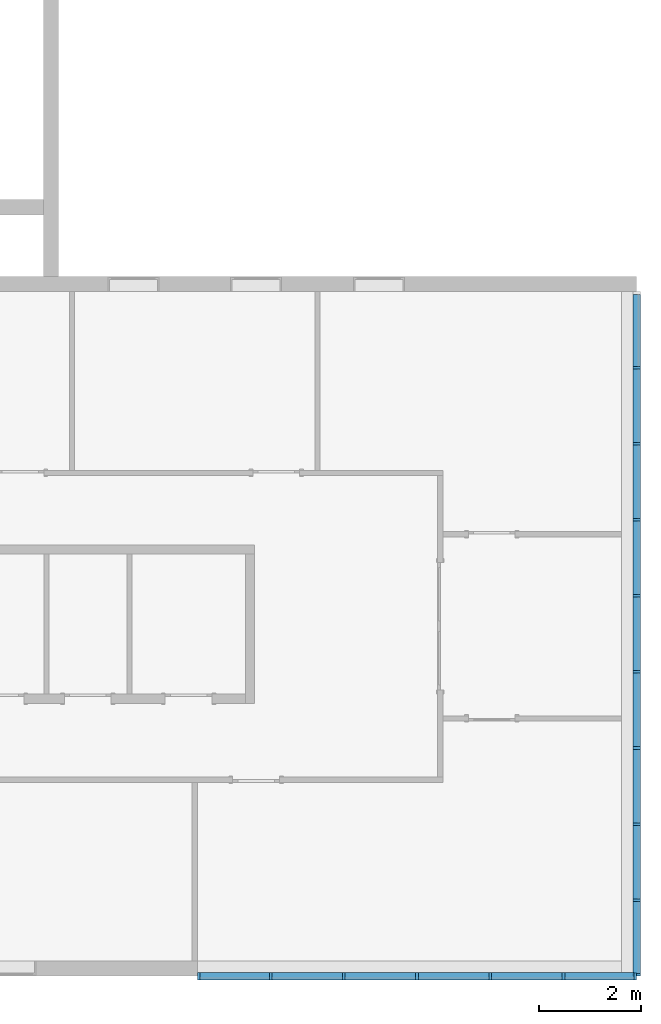
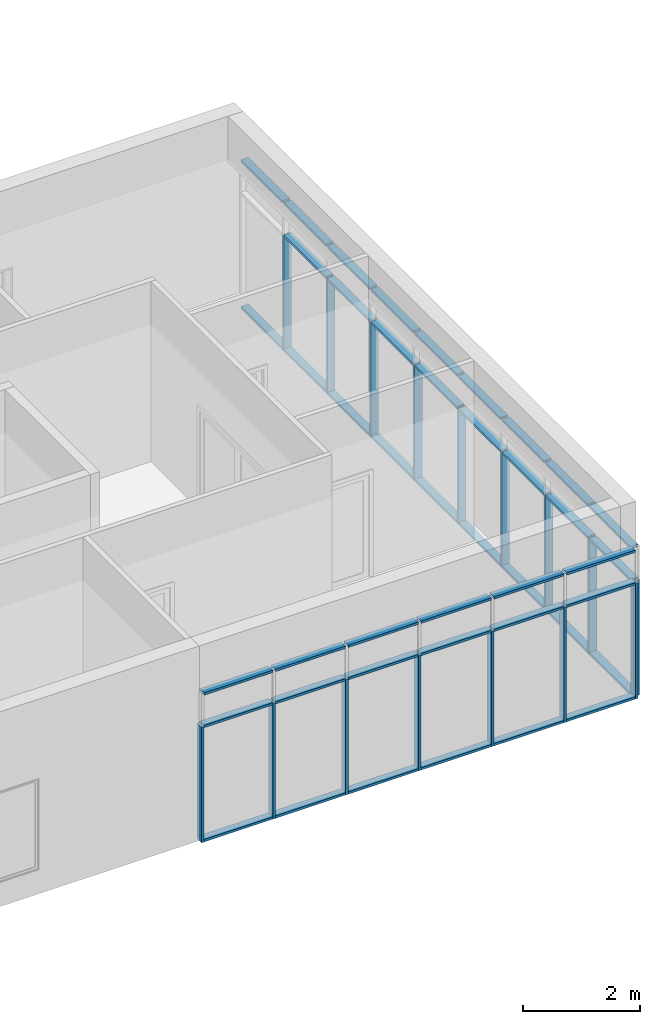
# One storey, part 2 of 13: 60 members, 2 elements without a shape of their own.
"""IFC2X3 building model written with IfcOpenShell, lengths in millimetres."""

from ifc_helpers import new_model, entity, si_unit, converted_unit, derived_unit, direction, frame, frame_2d, origin, origin_2d_with_axis, place, context, subcontext, project, spatial, rectangle, extrude, material, type_object, element, aggregate, save


model = new_model("IFC2X3")

# Units and contexts
model_context = context("Model", 3, precision=0.01, world=origin(), true_north=direction((6.12303176911189e-17, 1.0)))
context_of_model = context(None, 3, precision=0.01, world=origin(), true_north=direction((6.12303176911189e-17, 1.0)))
body_context = subcontext(model_context, "Body", "Model", "MODEL_VIEW")
ifc_project = project(units=[si_unit("LENGTHUNIT", "METRE", prefix="MILLI"), si_unit("AREAUNIT", "SQUARE_METRE"), si_unit("VOLUMEUNIT", "CUBIC_METRE"), converted_unit("PLANEANGLEUNIT", "DEGREE", entity("IfcRatioMeasure", 0.0174532925199433), si_unit("PLANEANGLEUNIT", "RADIAN"), dimensions=[0, 0, 0, 0, 0, 0, 0]), si_unit("MASSUNIT", "GRAM", prefix="KILO"), si_unit("TIMEUNIT", "SECOND"), si_unit("FREQUENCYUNIT", "HERTZ"), si_unit("THERMODYNAMICTEMPERATUREUNIT", "DEGREE_CELSIUS"), derived_unit("THERMALTRANSMITTANCEUNIT", [(si_unit("MASSUNIT", "GRAM", prefix="KILO"), 1), (si_unit("THERMODYNAMICTEMPERATUREUNIT", "KELVIN"), -1), (si_unit("TIMEUNIT", "SECOND"), -3)]), derived_unit("VOLUMETRICFLOWRATEUNIT", [(si_unit("LENGTHUNIT", "METRE"), 3), (si_unit("TIMEUNIT", "SECOND"), -1)]), si_unit("ELECTRICCURRENTUNIT", "AMPERE"), si_unit("ELECTRICVOLTAGEUNIT", "VOLT"), si_unit("POWERUNIT", "WATT"), si_unit("FORCEUNIT", "NEWTON", prefix="KILO"), si_unit("ILLUMINANCEUNIT", "LUX"), si_unit("LUMINOUSFLUXUNIT", "LUMEN"), si_unit("LUMINOUSINTENSITYUNIT", "CANDELA"), si_unit("PRESSUREUNIT", "PASCAL")], contexts=[model_context, context_of_model])

# Site, building, storey
site_placement = place(None, origin())
site = spatial("IfcSite", under=ifc_project, at=site_placement, CompositionType="ELEMENT")
building_placement = place(site_placement, origin())
building = spatial("IfcBuilding", under=site, at=building_placement, CompositionType="ELEMENT")
storey_placement = place(building_placement, frame((0.0, 0.0, 3750.0)))
storey = spatial("IfcBuildingStorey", under=building, at=storey_placement, Name="02. 2 etg.", CompositionType="ELEMENT", Elevation=3750.00000000068)

# Curtain wall, members
curtain_wall_type = type_object("IfcCurtainWallType", Name="Curtain Wall:Storefront", PredefinedType="NOTDEFINED")
curtain_wall_1_placement = place(storey_placement, frame((0.0, 0.0, -3750.0)))
curtain_wall_1 = element("IfcCurtainWall", 1, at=curtain_wall_1_placement, inside=storey, type_object=curtain_wall_type, Name="Curtain Wall:Storefront", ObjectType="Curtain Wall:Storefront")
ifc_material = material(Name="Aluminium")
member_1_placement = place(curtain_wall_1_placement, frame((41023.2357123495, -13390.0, 6500.0)))
member_1 = element("IfcMember", 2, at=member_1_placement, material=ifc_material, Name="Curtain Wall:Storefront:8486", ObjectType="Curtain Wall:Storefront:8486", context=body_context, shape_type="SweptSolid", body=[
    extrude(rectangle(XDim=1411.66666666667, YDim=150.000000000001, at=frame_2d((0.0, 4.32720526077901e-12), x_axis=(1.0, 0.0))), frame((75.0, 705.833333333333, 0.0), z_axis=(0.0, 0.0, 1.0), x_axis=(0.0, 1.0, 0.0)), (0.0, 0.0, 1.0), 49.9999999999995),
])
member_2_placement = place(curtain_wall_1_placement, frame((41023.2357123495, -1521.66666666667, 3450.0)))
member_2 = element("IfcMember", 3, at=member_2_placement, material=ifc_material, Name="Curtain Wall:Storefront:8486", ObjectType="Curtain Wall:Storefront:8486", context=body_context, shape_type="SweptSolid", body=[
    extrude(rectangle(XDim=1411.66666666667, YDim=150.000000000001, at=origin_2d_with_axis()), frame((75.0, 705.833333333333, 0.0), z_axis=(0.0, 0.0, 1.0), x_axis=(0.0, -1.0, 0.0)), (0.0, 0.0, 1.0), 50.0),
])
member_3_placement = place(curtain_wall_1_placement, frame((41023.2357123495, -13440.0, 3450.0)))
member_3 = element("IfcMember", 4, at=member_3_placement, material=ifc_material, Name="Curtain Wall:Storefront:8486", ObjectType="Curtain Wall:Storefront:8486", context=body_context, shape_type="SweptSolid", body=[
    extrude(rectangle(XDim=150.000000000001, YDim=50.0000000000016, at=origin_2d_with_axis()), frame((75.0, 25.0, 0.0)), (0.0, 0.0, 1.0), 2400.0),
])
member_4_placement = place(curtain_wall_1_placement, frame((41023.2357123495, -1521.66666666666, 6500.0)))
member_4 = element("IfcMember", 5, at=member_4_placement, material=ifc_material, Name="Curtain Wall:Storefront:8486", ObjectType="Curtain Wall:Storefront:8486", context=body_context, shape_type="SweptSolid", body=[
    extrude(rectangle(XDim=1411.66666666667, YDim=150.000000000001, at=origin_2d_with_axis()), frame((75.0, 705.833333333333, 0.0), z_axis=(0.0, 0.0, 1.0), x_axis=(0.0, 1.0, 0.0)), (0.0, 0.0, 1.0), 49.9999999999995),
])
member_5_placement = place(curtain_wall_1_placement, frame((41023.2357123495, -3008.33333333333, 6500.0)))
member_5 = element("IfcMember", 6, at=member_5_placement, material=ifc_material, Name="Curtain Wall:Storefront:8486", ObjectType="Curtain Wall:Storefront:8486", context=body_context, shape_type="SweptSolid", body=[
    extrude(rectangle(XDim=1436.66666666667, YDim=150.000000000001, at=frame_2d((0.0, 4.32720526077901e-12), x_axis=(1.0, 0.0))), frame((75.0, 718.333333333335, 0.0), z_axis=(0.0, 0.0, 1.0), x_axis=(0.0, 1.0, 0.0)), (0.0, 0.0, 1.0), 49.9999999999995),
])
member_6_placement = place(curtain_wall_1_placement, frame((41023.2357123495, -4495.0, 6500.0)))
member_6 = element("IfcMember", 7, at=member_6_placement, material=ifc_material, Name="Curtain Wall:Storefront:8486", ObjectType="Curtain Wall:Storefront:8486", context=body_context, shape_type="SweptSolid", body=[
    extrude(rectangle(XDim=1436.66666666667, YDim=150.000000000001, at=origin_2d_with_axis()), frame((75.0, 718.333333333334, 0.0), z_axis=(0.0, 0.0, 1.0), x_axis=(0.0, 1.0, 0.0)), (0.0, 0.0, 1.0), 49.9999999999995),
])
member_7_placement = place(curtain_wall_1_placement, frame((41023.2357123495, -5981.66666666667, 6500.0)))
member_7 = element("IfcMember", 8, at=member_7_placement, material=ifc_material, Name="Curtain Wall:Storefront:8486", ObjectType="Curtain Wall:Storefront:8486", context=body_context, shape_type="SweptSolid", body=[
    extrude(rectangle(XDim=1436.66666666667, YDim=150.000000000001, at=frame_2d((-5.11590769747272e-13, 0.0), x_axis=(1.0, 0.0))), frame((75.0, 718.333333333335, 0.0), z_axis=(0.0, 0.0, 1.0), x_axis=(0.0, 1.0, 0.0)), (0.0, 0.0, 1.0), 49.9999999999995),
])
member_8_placement = place(curtain_wall_1_placement, frame((41023.2357123495, -7468.33333333333, 6500.0)))
member_8 = element("IfcMember", 9, at=member_8_placement, material=ifc_material, Name="Curtain Wall:Storefront:8486", ObjectType="Curtain Wall:Storefront:8486", context=body_context, shape_type="SweptSolid", body=[
    extrude(rectangle(XDim=1436.66666666667, YDim=150.000000000001, at=frame_2d((-5.11590769747272e-13, 0.0), x_axis=(1.0, 0.0))), frame((75.0, 718.333333333335, 0.0), z_axis=(0.0, 0.0, 1.0), x_axis=(0.0, 1.0, 0.0)), (0.0, 0.0, 1.0), 49.9999999999995),
])
member_9_placement = place(curtain_wall_1_placement, frame((41023.2357123495, -8955.0, 6500.0)))
member_9 = element("IfcMember", 10, at=member_9_placement, material=ifc_material, Name="Curtain Wall:Storefront:8486", ObjectType="Curtain Wall:Storefront:8486", context=body_context, shape_type="SweptSolid", body=[
    extrude(rectangle(XDim=1436.66666666667, YDim=150.000000000001, at=frame_2d((5.6843418860808e-13, -4.32720526077901e-12), x_axis=(1.0, 0.0))), frame((75.0, 718.333333333335, 0.0), z_axis=(0.0, 0.0, 1.0), x_axis=(0.0, 1.0, 0.0)), (0.0, 0.0, 1.0), 49.9999999999995),
])
member_10_placement = place(curtain_wall_1_placement, frame((41023.2357123495, -10441.6666666667, 6500.0)))
member_10 = element("IfcMember", 11, at=member_10_placement, material=ifc_material, Name="Curtain Wall:Storefront:8486", ObjectType="Curtain Wall:Storefront:8486", context=body_context, shape_type="SweptSolid", body=[
    extrude(rectangle(XDim=1436.66666666667, YDim=150.000000000001, at=frame_2d((-5.11590769747272e-13, 0.0), x_axis=(1.0, 0.0))), frame((75.0, 718.333333333335, 0.0), z_axis=(0.0, 0.0, 1.0), x_axis=(0.0, 1.0, 0.0)), (0.0, 0.0, 1.0), 49.9999999999995),
])
member_11_placement = place(curtain_wall_1_placement, frame((41023.2357123495, -11928.3333333333, 6500.0)))
member_11 = element("IfcMember", 12, at=member_11_placement, material=ifc_material, Name="Curtain Wall:Storefront:8486", ObjectType="Curtain Wall:Storefront:8486", context=body_context, shape_type="SweptSolid", body=[
    extrude(rectangle(XDim=1436.66666666667, YDim=150.000000000001, at=origin_2d_with_axis()), frame((75.0, 718.333333333335, 0.0), z_axis=(0.0, 0.0, 1.0), x_axis=(0.0, 1.0, 0.0)), (0.0, 0.0, 1.0), 49.9999999999995),
])
member_12_placement = place(curtain_wall_1_placement, frame((41023.2357123495, -3008.33333333333, 3450.0)))
member_12 = element("IfcMember", 13, at=member_12_placement, material=ifc_material, Name="Curtain Wall:Storefront:8486", ObjectType="Curtain Wall:Storefront:8486", context=body_context, shape_type="SweptSolid", body=[
    extrude(rectangle(XDim=1436.66666666667, YDim=150.000000000001, at=frame_2d((0.0, -4.32720526077901e-12), x_axis=(1.0, 0.0))), frame((75.0, 718.333333333334, 0.0), z_axis=(0.0, 0.0, 1.0), x_axis=(0.0, -1.0, 0.0)), (0.0, 0.0, 1.0), 50.0),
])
member_13_placement = place(curtain_wall_1_placement, frame((41023.2357123495, -4495.0, 3450.0)))
member_13 = element("IfcMember", 14, at=member_13_placement, material=ifc_material, Name="Curtain Wall:Storefront:8486", ObjectType="Curtain Wall:Storefront:8486", context=body_context, shape_type="SweptSolid", body=[
    extrude(rectangle(XDim=1436.66666666667, YDim=150.000000000001, at=origin_2d_with_axis()), frame((75.0, 718.333333333334, 0.0), z_axis=(0.0, 0.0, 1.0), x_axis=(0.0, -1.0, 0.0)), (0.0, 0.0, 1.0), 50.0),
])
member_14_placement = place(curtain_wall_1_placement, frame((41023.2357123495, -5981.66666666667, 3450.0)))
member_14 = element("IfcMember", 15, at=member_14_placement, material=ifc_material, Name="Curtain Wall:Storefront:8486", ObjectType="Curtain Wall:Storefront:8486", context=body_context, shape_type="SweptSolid", body=[
    extrude(rectangle(XDim=1436.66666666667, YDim=150.000000000001, at=origin_2d_with_axis()), frame((75.0, 718.333333333334, 0.0), z_axis=(0.0, 0.0, 1.0), x_axis=(0.0, -1.0, 0.0)), (0.0, 0.0, 1.0), 50.0),
])
member_15_placement = place(curtain_wall_1_placement, frame((41023.2357123495, -7468.33333333333, 3450.0)))
member_15 = element("IfcMember", 16, at=member_15_placement, material=ifc_material, Name="Curtain Wall:Storefront:8486", ObjectType="Curtain Wall:Storefront:8486", context=body_context, shape_type="SweptSolid", body=[
    extrude(rectangle(XDim=1436.66666666667, YDim=150.000000000001, at=origin_2d_with_axis()), frame((75.0, 718.333333333334, 0.0), z_axis=(0.0, 0.0, 1.0), x_axis=(0.0, -1.0, 0.0)), (0.0, 0.0, 1.0), 50.0),
])
member_16_placement = place(curtain_wall_1_placement, frame((41023.2357123495, -8955.0, 3450.0)))
member_16 = element("IfcMember", 17, at=member_16_placement, material=ifc_material, Name="Curtain Wall:Storefront:8486", ObjectType="Curtain Wall:Storefront:8486", context=body_context, shape_type="SweptSolid", body=[
    extrude(rectangle(XDim=1436.66666666667, YDim=150.000000000001, at=frame_2d((5.11590769747272e-13, 4.32720526077901e-12), x_axis=(1.0, 0.0))), frame((75.0, 718.333333333335, 0.0), z_axis=(0.0, 0.0, 1.0), x_axis=(0.0, -1.0, 0.0)), (0.0, 0.0, 1.0), 50.0),
])
member_17_placement = place(curtain_wall_1_placement, frame((41023.2357123495, -10441.6666666667, 3450.0)))
member_17 = element("IfcMember", 18, at=member_17_placement, material=ifc_material, Name="Curtain Wall:Storefront:8486", ObjectType="Curtain Wall:Storefront:8486", context=body_context, shape_type="SweptSolid", body=[
    extrude(rectangle(XDim=1436.66666666667, YDim=150.000000000001, at=frame_2d((1.08002495835535e-12, 0.0), x_axis=(1.0, 0.0))), frame((75.0, 718.333333333335, 0.0), z_axis=(0.0, 0.0, 1.0), x_axis=(0.0, -1.0, 0.0)), (0.0, 0.0, 1.0), 50.0),
])
member_18_placement = place(curtain_wall_1_placement, frame((41023.2357123495, -11928.3333333333, 3450.0)))
member_18 = element("IfcMember", 19, at=member_18_placement, material=ifc_material, Name="Curtain Wall:Storefront:8486", ObjectType="Curtain Wall:Storefront:8486", context=body_context, shape_type="SweptSolid", body=[
    extrude(rectangle(XDim=1436.66666666667, YDim=150.000000000001, at=frame_2d((-1.08002495835535e-12, 0.0), x_axis=(1.0, 0.0))), frame((75.0, 718.333333333335, 0.0), z_axis=(0.0, 0.0, 1.0), x_axis=(0.0, -1.0, 0.0)), (0.0, 0.0, 1.0), 50.0),
])
member_19_placement = place(curtain_wall_1_placement, frame((41023.2357123495, -13390.0, 3450.0)))
member_19 = element("IfcMember", 20, at=member_19_placement, material=ifc_material, Name="Curtain Wall:Storefront:8486", ObjectType="Curtain Wall:Storefront:8486", context=body_context, shape_type="SweptSolid", body=[
    extrude(rectangle(XDim=1411.66666666667, YDim=150.000000000001, at=frame_2d((0.0, -4.32720526077901e-12), x_axis=(1.0, 0.0))), frame((75.0, 705.833333333333, 0.0), z_axis=(0.0, 0.0, 1.0), x_axis=(0.0, -1.0, 0.0)), (0.0, 0.0, 1.0), 50.0),
])
member_20_placement = place(curtain_wall_1_placement, frame((41023.2357123495, -3008.33333333333, 5825.0)))
member_20 = element("IfcMember", 21, at=member_20_placement, material=ifc_material, Name="Curtain Wall:Storefront:8486", ObjectType="Curtain Wall:Storefront:8486", context=body_context, shape_type="SweptSolid", body=[
    extrude(rectangle(XDim=1436.66666666667, YDim=150.000000000001, at=frame_2d((1.13686837721616e-13, 4.32720526077901e-12), x_axis=(1.0, 0.0))), frame((75.0, 718.333333333334, 0.0), z_axis=(0.0, 0.0, 1.0), x_axis=(0.0, 1.0, 0.0)), (0.0, 0.0, 1.0), 49.9999999999995),
])
member_21_placement = place(curtain_wall_1_placement, frame((41023.2357123495, -4495.0, 5825.0)))
member_21 = element("IfcMember", 22, at=member_21_placement, material=ifc_material, Name="Curtain Wall:Storefront:8486", ObjectType="Curtain Wall:Storefront:8486", context=body_context, shape_type="SweptSolid", body=[
    extrude(rectangle(XDim=1436.66666666667, YDim=150.000000000001, at=origin_2d_with_axis()), frame((75.0, 718.333333333334, 0.0), z_axis=(0.0, 0.0, 1.0), x_axis=(0.0, 1.0, 0.0)), (0.0, 0.0, 1.0), 49.9999999999995),
])
member_22_placement = place(curtain_wall_1_placement, frame((41023.2357123495, -5981.66666666667, 5825.0)))
member_22 = element("IfcMember", 23, at=member_22_placement, material=ifc_material, Name="Curtain Wall:Storefront:8486", ObjectType="Curtain Wall:Storefront:8486", context=body_context, shape_type="SweptSolid", body=[
    extrude(rectangle(XDim=1436.66666666667, YDim=150.000000000001, at=frame_2d((-5.11590769747272e-13, 0.0), x_axis=(1.0, 0.0))), frame((75.0, 718.333333333335, 0.0), z_axis=(0.0, 0.0, 1.0), x_axis=(0.0, 1.0, 0.0)), (0.0, 0.0, 1.0), 49.9999999999995),
])
member_23_placement = place(curtain_wall_1_placement, frame((41023.2357123495, -7468.33333333333, 5825.0)))
member_23 = element("IfcMember", 24, at=member_23_placement, material=ifc_material, Name="Curtain Wall:Storefront:8486", ObjectType="Curtain Wall:Storefront:8486", context=body_context, shape_type="SweptSolid", body=[
    extrude(rectangle(XDim=1436.66666666667, YDim=150.000000000001, at=frame_2d((5.11590769747272e-13, 0.0), x_axis=(1.0, 0.0))), frame((75.0, 718.333333333335, 0.0), z_axis=(0.0, 0.0, 1.0), x_axis=(0.0, 1.0, 0.0)), (0.0, 0.0, 1.0), 49.9999999999995),
])
member_24_placement = place(curtain_wall_1_placement, frame((41023.2357123495, -8955.0, 5825.0)))
member_24 = element("IfcMember", 25, at=member_24_placement, material=ifc_material, Name="Curtain Wall:Storefront:8486", ObjectType="Curtain Wall:Storefront:8486", context=body_context, shape_type="SweptSolid", body=[
    extrude(rectangle(XDim=1436.66666666667, YDim=150.000000000001, at=frame_2d((5.6843418860808e-13, -4.32720526077901e-12), x_axis=(1.0, 0.0))), frame((75.0, 718.333333333335, 0.0), z_axis=(0.0, 0.0, 1.0), x_axis=(0.0, 1.0, 0.0)), (0.0, 0.0, 1.0), 49.9999999999995),
])
member_25_placement = place(curtain_wall_1_placement, frame((41023.2357123495, -10441.6666666667, 5825.0)))
member_25 = element("IfcMember", 26, at=member_25_placement, material=ifc_material, Name="Curtain Wall:Storefront:8486", ObjectType="Curtain Wall:Storefront:8486", context=body_context, shape_type="SweptSolid", body=[
    extrude(rectangle(XDim=1436.66666666667, YDim=150.000000000001, at=frame_2d((-5.11590769747272e-13, 0.0), x_axis=(1.0, 0.0))), frame((75.0, 718.333333333335, 0.0), z_axis=(0.0, 0.0, 1.0), x_axis=(0.0, 1.0, 0.0)), (0.0, 0.0, 1.0), 49.9999999999995),
])
member_26_placement = place(curtain_wall_1_placement, frame((41023.2357123495, -11928.3333333333, 5825.0)))
member_26 = element("IfcMember", 27, at=member_26_placement, material=ifc_material, Name="Curtain Wall:Storefront:8486", ObjectType="Curtain Wall:Storefront:8486", context=body_context, shape_type="SweptSolid", body=[
    extrude(rectangle(XDim=1436.66666666667, YDim=150.000000000001, at=frame_2d((-1.08002495835535e-12, 0.0), x_axis=(1.0, 0.0))), frame((75.0, 718.333333333335, 0.0), z_axis=(0.0, 0.0, 1.0), x_axis=(0.0, 1.0, 0.0)), (0.0, 0.0, 1.0), 49.9999999999995),
])
member_27_placement = place(curtain_wall_1_placement, frame((41023.2357123495, -13390.0, 5825.0)))
member_27 = element("IfcMember", 28, at=member_27_placement, material=ifc_material, Name="Curtain Wall:Storefront:8486", ObjectType="Curtain Wall:Storefront:8486", context=body_context, shape_type="SweptSolid", body=[
    extrude(rectangle(XDim=1411.66666666667, YDim=150.000000000001, at=frame_2d((0.0, 4.32720526077901e-12), x_axis=(1.0, 0.0))), frame((75.0, 705.833333333333, 0.0), z_axis=(0.0, 0.0, 1.0), x_axis=(0.0, 1.0, 0.0)), (0.0, 0.0, 1.0), 49.9999999999995),
])
member_28_placement = place(curtain_wall_1_placement, frame((41023.2357123495, -1571.66666666667, 3450.0)))
member_28 = element("IfcMember", 29, at=member_28_placement, material=ifc_material, Name="Curtain Wall:Storefront:8486", ObjectType="Curtain Wall:Storefront:8486", context=body_context, shape_type="SweptSolid", body=[
    extrude(rectangle(XDim=150.000000000001, YDim=50.0, at=frame_2d((0.0, -1.36779476633819e-13), x_axis=(1.0, 0.0))), frame((75.0, 25.0, 0.0)), (0.0, 0.0, 1.0), 2400.0),
])
member_29_placement = place(curtain_wall_1_placement, frame((41023.2357123495, -3058.33333333333, 3450.0)))
member_29 = element("IfcMember", 30, at=member_29_placement, material=ifc_material, Name="Curtain Wall:Storefront:8486", ObjectType="Curtain Wall:Storefront:8486", context=body_context, shape_type="SweptSolid", body=[
    extrude(rectangle(XDim=150.000000000001, YDim=50.0, at=frame_2d((0.0, 2.71782596428238e-13), x_axis=(1.0, 0.0))), frame((75.0, 25.0, 0.0)), (0.0, 0.0, 1.0), 2400.0),
])
member_30_placement = place(curtain_wall_1_placement, frame((41023.2357123495, -4545.0, 3450.0)))
member_30 = element("IfcMember", 31, at=member_30_placement, material=ifc_material, Name="Curtain Wall:Storefront:8486", ObjectType="Curtain Wall:Storefront:8486", context=body_context, shape_type="SweptSolid", body=[
    extrude(rectangle(XDim=150.000000000001, YDim=50.0, at=frame_2d((0.0, -2.71782596428238e-13), x_axis=(1.0, 0.0))), frame((75.0, 25.0, 0.0)), (0.0, 0.0, 1.0), 2400.0),
])
member_31_placement = place(curtain_wall_1_placement, frame((41023.2357123495, -6031.66666666667, 3450.0)))
member_31 = element("IfcMember", 32, at=member_31_placement, material=ifc_material, Name="Curtain Wall:Storefront:8486", ObjectType="Curtain Wall:Storefront:8486", context=body_context, shape_type="SweptSolid", body=[
    extrude(rectangle(XDim=150.000000000001, YDim=50.0000000000005, at=frame_2d((0.0, -5.41788836017076e-13), x_axis=(1.0, 0.0))), frame((75.0, 25.0, 0.0)), (0.0, 0.0, 1.0), 2400.0),
])
member_32_placement = place(curtain_wall_1_placement, frame((41023.2357123495, -7518.33333333333, 3450.0)))
member_32 = element("IfcMember", 33, at=member_32_placement, material=ifc_material, Name="Curtain Wall:Storefront:8486", ObjectType="Curtain Wall:Storefront:8486", context=body_context, shape_type="SweptSolid", body=[
    extrude(rectangle(XDim=150.000000000001, YDim=50.0000000000005, at=frame_2d((0.0, 5.41788836017076e-13), x_axis=(1.0, 0.0))), frame((75.0, 25.0, 0.0)), (0.0, 0.0, 1.0), 2400.0),
])
member_33_placement = place(curtain_wall_1_placement, frame((41023.2357123495, -9005.0, 3450.0)))
member_33 = element("IfcMember", 34, at=member_33_placement, material=ifc_material, Name="Curtain Wall:Storefront:8486", ObjectType="Curtain Wall:Storefront:8486", context=body_context, shape_type="SweptSolid", body=[
    extrude(rectangle(XDim=150.000000000001, YDim=50.0000000000005, at=frame_2d((0.0, -5.41788836017076e-13), x_axis=(1.0, 0.0))), frame((75.0, 25.0, 0.0)), (0.0, 0.0, 1.0), 2400.0),
])
member_34_placement = place(curtain_wall_1_placement, frame((41023.2357123495, -10491.6666666667, 3450.0)))
member_34 = element("IfcMember", 35, at=member_34_placement, material=ifc_material, Name="Curtain Wall:Storefront:8486", ObjectType="Curtain Wall:Storefront:8486", context=body_context, shape_type="SweptSolid", body=[
    extrude(rectangle(XDim=150.000000000001, YDim=49.9999999999995, at=frame_2d((0.0, -1.08357767203415e-12), x_axis=(1.0, 0.0))), frame((75.0, 25.0, 0.0)), (0.0, 0.0, 1.0), 2400.0),
])
member_35_placement = place(curtain_wall_1_placement, frame((41023.2357123495, -11978.3333333333, 3450.0)))
member_35 = element("IfcMember", 36, at=member_35_placement, material=ifc_material, Name="Curtain Wall:Storefront:8486", ObjectType="Curtain Wall:Storefront:8486", context=body_context, shape_type="SweptSolid", body=[
    extrude(rectangle(XDim=150.000000000001, YDim=49.9999999999995, at=frame_2d((0.0, -1.08357767203415e-12), x_axis=(1.0, 0.0))), frame((75.0, 25.0, 0.0)), (0.0, 0.0, 1.0), 2400.0),
])
aggregate(curtain_wall_1, [member_1, member_2, member_3, member_4, member_5, member_6, member_7, member_8, member_9, member_10, member_11, member_12, member_13, member_14, member_15, member_16, member_17, member_18, member_19, member_20, member_21, member_22, member_23, member_24, member_25, member_26, member_27, member_28, member_29, member_30, member_31, member_32, member_33, member_34, member_35])

curtain_wall_2_placement = place(storey_placement, frame((0.0, 0.0, -3750.0)))
curtain_wall_2 = element("IfcCurtainWall", 37, at=curtain_wall_2_placement, inside=storey, type_object=curtain_wall_type, Name="Curtain Wall:Storefront", ObjectType="Curtain Wall:Storefront")
member_36_placement = place(curtain_wall_2_placement, frame((32558.2357123495, -13515.0, 6500.0)))
member_36 = element("IfcMember", 38, at=member_36_placement, material=ifc_material, Name="Curtain Wall:Storefront:8486", ObjectType="Curtain Wall:Storefront:8486", context=body_context, shape_type="SweptSolid", body=[
    extrude(rectangle(XDim=1356.66666666667, YDim=150.000000000001, at=origin_2d_with_axis()), frame((678.333333333335, 75.0, 0.0)), (0.0, 0.0, 1.0), 49.9999999999995),
])
member_37_placement = place(curtain_wall_2_placement, frame((39691.5690456828, -13515.0, 3450.0)))
member_37 = element("IfcMember", 39, at=member_37_placement, material=ifc_material, Name="Curtain Wall:Storefront:8486", ObjectType="Curtain Wall:Storefront:8486", context=body_context, shape_type="SweptSolid", body=[
    extrude(rectangle(XDim=1356.66666666667, YDim=150.000000000001, at=frame_2d((0.0, 2.16715534406831e-12), x_axis=(1.0, 0.0))), frame((678.333333333335, 75.0, 0.0), z_axis=(0.0, 0.0, 1.0), x_axis=(-1.0, 0.0, 0.0)), (0.0, 0.0, 1.0), 50.0),
])
member_38_placement = place(curtain_wall_2_placement, frame((32508.2357123495, -13515.0, 3450.0)))
member_38 = element("IfcMember", 40, at=member_38_placement, material=ifc_material, Name="Curtain Wall:Storefront:8486", ObjectType="Curtain Wall:Storefront:8486", context=body_context, shape_type="SweptSolid", body=[
    extrude(rectangle(XDim=149.999999999998, YDim=50.0000000000016, at=frame_2d((-1.08002495835535e-12, -2.16715534406831e-12), x_axis=(1.0, 0.0))), frame((25.0, 75.0, 0.0), z_axis=(0.0, 0.0, 1.0), x_axis=(0.0, -1.0, 0.0)), (0.0, 0.0, 1.0), 2400.0),
])
member_39_placement = place(curtain_wall_2_placement, frame((39691.5690456828, -13515.0, 6500.0)))
member_39 = element("IfcMember", 41, at=member_39_placement, material=ifc_material, Name="Curtain Wall:Storefront:8486", ObjectType="Curtain Wall:Storefront:8486", context=body_context, shape_type="SweptSolid", body=[
    extrude(rectangle(XDim=1356.66666666667, YDim=150.000000000001, at=origin_2d_with_axis()), frame((678.333333333335, 75.0, 0.0)), (0.0, 0.0, 1.0), 49.9999999999995),
])
member_40_placement = place(curtain_wall_2_placement, frame((38259.9023790162, -13515.0, 6500.0)))
member_40 = element("IfcMember", 42, at=member_40_placement, material=ifc_material, Name="Curtain Wall:Storefront:8486", ObjectType="Curtain Wall:Storefront:8486", context=body_context, shape_type="SweptSolid", body=[
    extrude(rectangle(XDim=1381.66666666667, YDim=150.000000000001, at=frame_2d((-2.1600499167107e-12, 2.16715534406831e-12), x_axis=(1.0, 0.0))), frame((690.833333333332, 75.0, 0.0)), (0.0, 0.0, 1.0), 49.9999999999995),
])
member_41_placement = place(curtain_wall_2_placement, frame((36828.2357123495, -13515.0, 6500.0)))
member_41 = element("IfcMember", 43, at=member_41_placement, material=ifc_material, Name="Curtain Wall:Storefront:8486", ObjectType="Curtain Wall:Storefront:8486", context=body_context, shape_type="SweptSolid", body=[
    extrude(rectangle(XDim=1381.66666666667, YDim=150.000000000001, at=frame_2d((-2.1600499167107e-12, 0.0), x_axis=(1.0, 0.0))), frame((690.833333333332, 75.0, 0.0)), (0.0, 0.0, 1.0), 49.9999999999995),
])
member_42_placement = place(curtain_wall_2_placement, frame((38259.9023790162, -13515.0, 3450.0)))
member_42 = element("IfcMember", 44, at=member_42_placement, material=ifc_material, Name="Curtain Wall:Storefront:8486", ObjectType="Curtain Wall:Storefront:8486", context=body_context, shape_type="SweptSolid", body=[
    extrude(rectangle(XDim=1381.66666666667, YDim=150.000000000001, at=frame_2d((-2.1600499167107e-12, 0.0), x_axis=(1.0, 0.0))), frame((690.833333333337, 75.0, 0.0), z_axis=(0.0, 0.0, 1.0), x_axis=(-1.0, 0.0, 0.0)), (0.0, 0.0, 1.0), 50.0),
])
member_43_placement = place(curtain_wall_2_placement, frame((36828.2357123495, -13515.0, 3450.0)))
member_43 = element("IfcMember", 45, at=member_43_placement, material=ifc_material, Name="Curtain Wall:Storefront:8486", ObjectType="Curtain Wall:Storefront:8486", context=body_context, shape_type="SweptSolid", body=[
    extrude(rectangle(XDim=1381.66666666667, YDim=150.000000000001, at=frame_2d((2.1600499167107e-12, -2.16715534406831e-12), x_axis=(1.0, 0.0))), frame((690.833333333332, 75.0, 0.0), z_axis=(0.0, 0.0, 1.0), x_axis=(-1.0, 0.0, 0.0)), (0.0, 0.0, 1.0), 50.0),
])
member_44_placement = place(curtain_wall_2_placement, frame((35396.5690456828, -13515.0, 3450.0)))
member_44 = element("IfcMember", 46, at=member_44_placement, material=ifc_material, Name="Curtain Wall:Storefront:8486", ObjectType="Curtain Wall:Storefront:8486", context=body_context, shape_type="SweptSolid", body=[
    extrude(rectangle(XDim=1381.66666666667, YDim=150.000000000001, at=frame_2d((2.1600499167107e-12, -1.08713038571295e-12), x_axis=(1.0, 0.0))), frame((690.833333333332, 75.0, 0.0), z_axis=(0.0, 0.0, 1.0), x_axis=(-1.0, 0.0, 0.0)), (0.0, 0.0, 1.0), 50.0),
])
member_45_placement = place(curtain_wall_2_placement, frame((41048.2357123495, -13515.0, 3450.0)))
member_45 = element("IfcMember", 47, at=member_45_placement, material=ifc_material, Name="Curtain Wall:Storefront:8486", ObjectType="Curtain Wall:Storefront:8486", context=body_context, shape_type="SweptSolid", body=[
    extrude(rectangle(XDim=49.9999999999973, YDim=150.000000000001, at=frame_2d((4.33253433129721e-12, 0.0), x_axis=(1.0, 0.0))), frame((25.0, 75.0, 0.0), z_axis=(0.0, 0.0, 1.0), x_axis=(-1.0, 0.0, 0.0)), (0.0, 0.0, 1.0), 2400.0),
])
member_46_placement = place(curtain_wall_2_placement, frame((39691.5690456828, -13515.0, 5825.0)))
member_46 = element("IfcMember", 48, at=member_46_placement, material=ifc_material, Name="Curtain Wall:Storefront:8486", ObjectType="Curtain Wall:Storefront:8486", context=body_context, shape_type="SweptSolid", body=[
    extrude(rectangle(XDim=1356.66666666667, YDim=150.000000000001, at=origin_2d_with_axis()), frame((678.333333333335, 75.0, 0.0)), (0.0, 0.0, 1.0), 49.9999999999995),
])
member_47_placement = place(curtain_wall_2_placement, frame((38259.9023790162, -13515.0, 5825.0)))
member_47 = element("IfcMember", 49, at=member_47_placement, material=ifc_material, Name="Curtain Wall:Storefront:8486", ObjectType="Curtain Wall:Storefront:8486", context=body_context, shape_type="SweptSolid", body=[
    extrude(rectangle(XDim=1381.66666666667, YDim=150.000000000001, at=frame_2d((-2.1600499167107e-12, 2.16715534406831e-12), x_axis=(1.0, 0.0))), frame((690.833333333332, 75.0, 0.0)), (0.0, 0.0, 1.0), 49.9999999999995),
])
member_48_placement = place(curtain_wall_2_placement, frame((36828.2357123495, -13515.0, 5825.0)))
member_48 = element("IfcMember", 50, at=member_48_placement, material=ifc_material, Name="Curtain Wall:Storefront:8486", ObjectType="Curtain Wall:Storefront:8486", context=body_context, shape_type="SweptSolid", body=[
    extrude(rectangle(XDim=1381.66666666667, YDim=150.000000000001, at=frame_2d((-2.1600499167107e-12, 0.0), x_axis=(1.0, 0.0))), frame((690.833333333332, 75.0, 0.0)), (0.0, 0.0, 1.0), 49.9999999999995),
])
member_49_placement = place(curtain_wall_2_placement, frame((35396.5690456828, -13515.0, 5825.0)))
member_49 = element("IfcMember", 51, at=member_49_placement, material=ifc_material, Name="Curtain Wall:Storefront:8486", ObjectType="Curtain Wall:Storefront:8486", context=body_context, shape_type="SweptSolid", body=[
    extrude(rectangle(XDim=1381.66666666667, YDim=149.999999999998, at=frame_2d((-2.1600499167107e-12, 0.0), x_axis=(1.0, 0.0))), frame((690.833333333332, 75.0, 0.0)), (0.0, 0.0, 1.0), 49.9999999999995),
])
member_50_placement = place(curtain_wall_2_placement, frame((39641.5690456828, -13515.0, 3450.0)))
member_50 = element("IfcMember", 52, at=member_50_placement, material=ifc_material, Name="Curtain Wall:Storefront:8486", ObjectType="Curtain Wall:Storefront:8486", context=body_context, shape_type="SweptSolid", body=[
    extrude(rectangle(XDim=149.999999999998, YDim=50.000000000006, at=frame_2d((1.08002495835535e-12, 0.0), x_axis=(1.0, 0.0))), frame((25.0, 75.0, 0.0), z_axis=(0.0, 0.0, 1.0), x_axis=(0.0, -1.0, 0.0)), (0.0, 0.0, 1.0), 2400.0),
])
member_51_placement = place(curtain_wall_2_placement, frame((38209.9023790161, -13515.0, 3450.0)))
member_51 = element("IfcMember", 53, at=member_51_placement, material=ifc_material, Name="Curtain Wall:Storefront:8486", ObjectType="Curtain Wall:Storefront:8486", context=body_context, shape_type="SweptSolid", body=[
    extrude(rectangle(XDim=149.999999999998, YDim=49.9999999999973, at=frame_2d((1.08002495835535e-12, 2.16715534406831e-12), x_axis=(1.0, 0.0))), frame((25.0, 75.0, 0.0), z_axis=(0.0, 0.0, 1.0), x_axis=(0.0, -1.0, 0.0)), (0.0, 0.0, 1.0), 2400.0),
])
member_52_placement = place(curtain_wall_2_placement, frame((36778.2357123495, -13515.0, 3450.0)))
member_52 = element("IfcMember", 54, at=member_52_placement, material=ifc_material, Name="Curtain Wall:Storefront:8486", ObjectType="Curtain Wall:Storefront:8486", context=body_context, shape_type="SweptSolid", body=[
    extrude(rectangle(XDim=149.999999999998, YDim=49.9999999999973, at=frame_2d((1.08002495835535e-12, 2.16715534406831e-12), x_axis=(1.0, 0.0))), frame((25.0, 75.0, 0.0), z_axis=(0.0, 0.0, 1.0), x_axis=(0.0, -1.0, 0.0)), (0.0, 0.0, 1.0), 2400.0),
])
member_53_placement = place(curtain_wall_2_placement, frame((35396.5690456828, -13515.0, 6500.0)))
member_53 = element("IfcMember", 55, at=member_53_placement, material=ifc_material, Name="Curtain Wall:Storefront:8486", ObjectType="Curtain Wall:Storefront:8486", context=body_context, shape_type="SweptSolid", body=[
    extrude(rectangle(XDim=1381.66666666667, YDim=150.000000000001, at=frame_2d((-2.1600499167107e-12, 1.08713038571295e-12), x_axis=(1.0, 0.0))), frame((690.833333333332, 75.0, 0.0)), (0.0, 0.0, 1.0), 49.9999999999995),
])
member_54_placement = place(curtain_wall_2_placement, frame((33964.9023790161, -13515.0, 3450.0)))
member_54 = element("IfcMember", 56, at=member_54_placement, material=ifc_material, Name="Curtain Wall:Storefront:8486", ObjectType="Curtain Wall:Storefront:8486", context=body_context, shape_type="SweptSolid", body=[
    extrude(rectangle(XDim=1381.66666666667, YDim=150.000000000001, at=frame_2d((2.1600499167107e-12, 0.0), x_axis=(1.0, 0.0))), frame((690.833333333332, 75.0, 0.0), z_axis=(0.0, 0.0, 1.0), x_axis=(-1.0, 0.0, 0.0)), (0.0, 0.0, 1.0), 50.0),
])
member_55_placement = place(curtain_wall_2_placement, frame((33964.9023790161, -13515.0, 5825.0)))
member_55 = element("IfcMember", 57, at=member_55_placement, material=ifc_material, Name="Curtain Wall:Storefront:8486", ObjectType="Curtain Wall:Storefront:8486", context=body_context, shape_type="SweptSolid", body=[
    extrude(rectangle(XDim=1381.66666666667, YDim=149.999999999998, at=frame_2d((-2.1600499167107e-12, -1.08002495835535e-12), x_axis=(1.0, 0.0))), frame((690.833333333332, 75.0, 0.0)), (0.0, 0.0, 1.0), 49.9999999999995),
])
member_56_placement = place(curtain_wall_2_placement, frame((35346.5690456828, -13515.0, 3450.0)))
member_56 = element("IfcMember", 58, at=member_56_placement, material=ifc_material, Name="Curtain Wall:Storefront:8486", ObjectType="Curtain Wall:Storefront:8486", context=body_context, shape_type="SweptSolid", body=[
    extrude(rectangle(XDim=149.999999999998, YDim=49.9999999999973, at=frame_2d((-1.08002495835535e-12, 2.16715534406831e-12), x_axis=(1.0, 0.0))), frame((25.0, 75.0, 0.0), z_axis=(0.0, 0.0, 1.0), x_axis=(0.0, -1.0, 0.0)), (0.0, 0.0, 1.0), 2400.0),
])
member_57_placement = place(curtain_wall_2_placement, frame((33964.9023790161, -13515.0, 6500.0)))
member_57 = element("IfcMember", 59, at=member_57_placement, material=ifc_material, Name="Curtain Wall:Storefront:8486", ObjectType="Curtain Wall:Storefront:8486", context=body_context, shape_type="SweptSolid", body=[
    extrude(rectangle(XDim=1381.66666666667, YDim=150.000000000001, at=frame_2d((-2.1600499167107e-12, 0.0), x_axis=(1.0, 0.0))), frame((690.833333333332, 75.0, 0.0)), (0.0, 0.0, 1.0), 49.9999999999995),
])
member_58_placement = place(curtain_wall_2_placement, frame((32558.2357123495, -13515.0, 3450.0)))
member_58 = element("IfcMember", 60, at=member_58_placement, material=ifc_material, Name="Curtain Wall:Storefront:8486", ObjectType="Curtain Wall:Storefront:8486", context=body_context, shape_type="SweptSolid", body=[
    extrude(rectangle(XDim=1356.66666666667, YDim=150.000000000001, at=origin_2d_with_axis()), frame((678.333333333335, 75.0, 0.0), z_axis=(0.0, 0.0, 1.0), x_axis=(-1.0, 0.0, 0.0)), (0.0, 0.0, 1.0), 50.0),
])
member_59_placement = place(curtain_wall_2_placement, frame((32558.2357123495, -13515.0, 5825.0)))
member_59 = element("IfcMember", 61, at=member_59_placement, material=ifc_material, Name="Curtain Wall:Storefront:8486", ObjectType="Curtain Wall:Storefront:8486", context=body_context, shape_type="SweptSolid", body=[
    extrude(rectangle(XDim=1356.66666666667, YDim=149.999999999998, at=frame_2d((0.0, 1.08002495835535e-12), x_axis=(1.0, 0.0))), frame((678.333333333335, 75.0, 0.0)), (0.0, 0.0, 1.0), 49.9999999999995),
])
member_60_placement = place(curtain_wall_2_placement, frame((33914.9023790161, -13515.0, 3450.0)))
member_60 = element("IfcMember", 62, at=member_60_placement, material=ifc_material, Name="Curtain Wall:Storefront:8486", ObjectType="Curtain Wall:Storefront:8486", context=body_context, shape_type="SweptSolid", body=[
    extrude(rectangle(XDim=149.999999999998, YDim=49.9999999999973, at=frame_2d((1.08002495835535e-12, 2.16715534406831e-12), x_axis=(1.0, 0.0))), frame((25.0, 75.0, 0.0), z_axis=(0.0, 0.0, 1.0), x_axis=(0.0, -1.0, 0.0)), (0.0, 0.0, 1.0), 2400.0),
])
aggregate(curtain_wall_2, [member_36, member_37, member_38, member_39, member_40, member_41, member_42, member_43, member_44, member_45, member_46, member_47, member_48, member_49, member_50, member_51, member_52, member_53, member_54, member_55, member_56, member_57, member_58, member_59, member_60])

save(model, "model.ifc")
